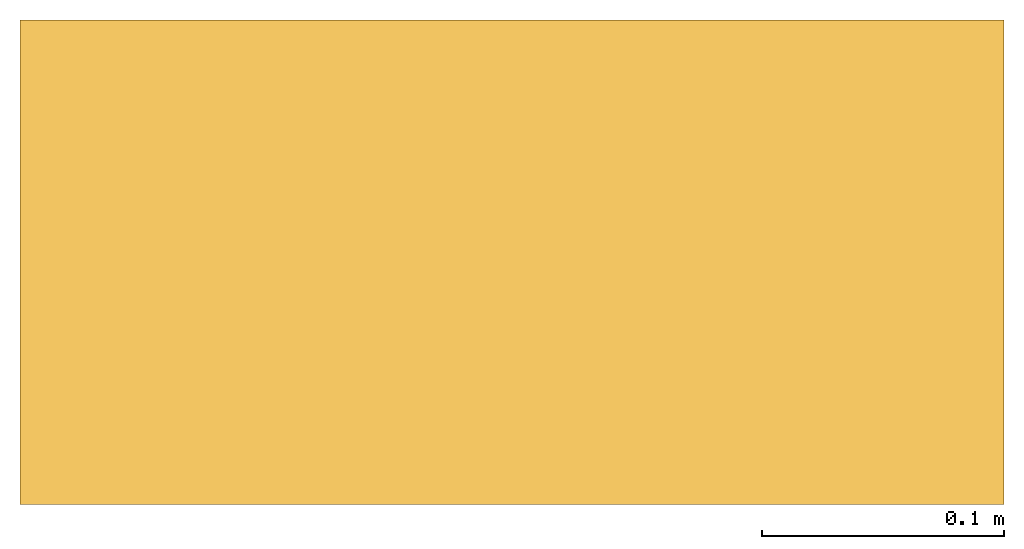
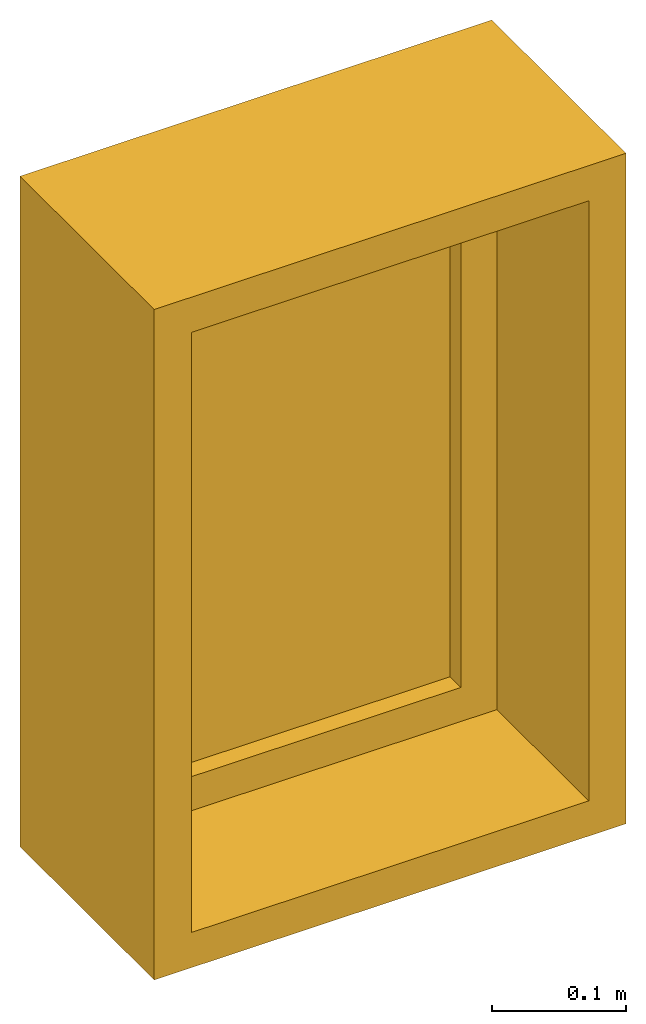
# One storey: 1 window.
"""IFC4 building model written with IfcOpenShell, lengths in millimetres."""

from ifc_helpers import new_model, entity, si_unit, converted_unit, derived_unit, direction, frame, origin, origin_with_axes, origin_2d_with_axis, place, context, subcontext, project, spatial, polyline, rectangle, outline, extrude, source, transform, mapped, material, constituent, constituent_set, type_object, type_shapes, element, save


model = new_model("IFC4")

# Units and contexts
model_context = context("Model", 3, precision=0.01, world=origin(), true_north=direction((6.12303176911189e-17, 1.0)))
body_context = subcontext(model_context, "Body", "Model", "MODEL_VIEW")
ifc_project = project(units=[si_unit("LENGTHUNIT", "METRE", prefix="MILLI"), si_unit("AREAUNIT", "SQUARE_METRE"), si_unit("VOLUMEUNIT", "CUBIC_METRE"), converted_unit("PLANEANGLEUNIT", "DEGREE", entity("IfcRatioMeasure", 0.0174532925199433), si_unit("PLANEANGLEUNIT", "RADIAN"), dimensions=[0, 0, 0, 0, 0, 0, 0]), si_unit("MASSUNIT", "GRAM", prefix="KILO"), derived_unit("MASSDENSITYUNIT", [(si_unit("MASSUNIT", "GRAM", prefix="KILO"), 1), (si_unit("LENGTHUNIT", "METRE"), -3)]), derived_unit("MOMENTOFINERTIAUNIT", [(si_unit("LENGTHUNIT", "METRE"), 4)]), si_unit("TIMEUNIT", "SECOND"), si_unit("FREQUENCYUNIT", "HERTZ"), si_unit("THERMODYNAMICTEMPERATUREUNIT", "DEGREE_CELSIUS"), derived_unit("THERMALTRANSMITTANCEUNIT", [(si_unit("MASSUNIT", "GRAM", prefix="KILO"), 1), (si_unit("THERMODYNAMICTEMPERATUREUNIT", "KELVIN"), -1), (si_unit("TIMEUNIT", "SECOND"), -3)]), derived_unit("VOLUMETRICFLOWRATEUNIT", [(si_unit("LENGTHUNIT", "METRE"), 3), (si_unit("TIMEUNIT", "SECOND"), -1)]), si_unit("ELECTRICCURRENTUNIT", "AMPERE"), si_unit("ELECTRICVOLTAGEUNIT", "VOLT"), si_unit("POWERUNIT", "WATT"), si_unit("FORCEUNIT", "NEWTON", prefix="KILO"), si_unit("ILLUMINANCEUNIT", "LUX"), si_unit("LUMINOUSFLUXUNIT", "LUMEN"), si_unit("LUMINOUSINTENSITYUNIT", "CANDELA"), derived_unit("USERDEFINED", [(si_unit("MASSUNIT", "GRAM", prefix="KILO"), -1), (si_unit("LENGTHUNIT", "METRE"), -2), (si_unit("TIMEUNIT", "SECOND"), 3), (si_unit("LUMINOUSFLUXUNIT", "LUMEN"), 1)]), derived_unit("LINEARVELOCITYUNIT", [(si_unit("LENGTHUNIT", "METRE"), 1), (si_unit("TIMEUNIT", "SECOND"), -1)]), si_unit("PRESSUREUNIT", "PASCAL"), derived_unit("USERDEFINED", [(si_unit("LENGTHUNIT", "METRE"), -2), (si_unit("MASSUNIT", "GRAM", prefix="KILO"), 1), (si_unit("TIMEUNIT", "SECOND"), -2)]), derived_unit("LINEARFORCEUNIT", [(si_unit("MASSUNIT", "GRAM", prefix="KILO"), 1), (si_unit("LENGTHUNIT", "METRE"), 1), (si_unit("TIMEUNIT", "SECOND"), -2), (si_unit("LENGTHUNIT", "METRE"), -1)]), derived_unit("PLANARFORCEUNIT", [(si_unit("MASSUNIT", "GRAM", prefix="KILO"), 1), (si_unit("LENGTHUNIT", "METRE"), 1), (si_unit("TIMEUNIT", "SECOND"), -2), (si_unit("LENGTHUNIT", "METRE"), -2)])], contexts=[model_context])

# Site, building, storey
site_placement = place(None, origin())
site = spatial("IfcSite", under=ifc_project, at=site_placement, CompositionType="ELEMENT")
building_placement = place(site_placement, origin())
building = spatial("IfcBuilding", under=site, at=building_placement, CompositionType="ELEMENT")
storey_placement = place(building_placement, origin())
storey = spatial("IfcBuildingStorey", under=building, at=storey_placement, Name="Niveau 1", CompositionType="ELEMENT", Elevation=0.0)

# Window
ifc_material_1 = material(Category="Pas d")
ifc_constituent_1 = constituent(ifc_material_1, Category="Pas d")
ifc_material_2 = material(Name="Verre 441", Category="Pas d")
ifc_constituent_2 = constituent(ifc_material_2, Name="Verre 441", Category="Pas d")
ifc_constituent_set = constituent_set(constituents=[ifc_constituent_1, ifc_constituent_2])
window_type = type_object("IfcWindowType", Name="Fixe:0406 x 0610mm:0406 x 0610mm : Fixe:0406 x 0610mm", ParameterTakesPrecedence=False, PartitioningType="NOTDEFINED", PredefinedType="WINDOW", material=ifc_constituent_set)
shared_shape = source(origin(), body_context, "Body", "SweptSolid", [
    extrude(outline(polyline([(-305.0, -203.0), (305.0, -203.0), (305.0, 203.0), (-305.0, 203.0), (-305.0, -203.0)]), holes=[polyline([(273.0, 171.0), (273.0, -171.0), (-273.0, -171.0), (-273.0, 171.0), (273.0, 171.0)])]), frame((203.0, 2.0, 305.0), z_axis=(0.0, 1.0, 0.0), x_axis=(0.0, 0.0, -1.0)), (0.0, 0.0, 1.0), 136.999999999973),
    extrude(outline(polyline([(-305.0, -203.0), (305.0, -203.0), (305.0, 203.0), (-305.0, 203.0), (-305.0, -203.0)]), holes=[polyline([(286.0, 184.0), (286.0, -184.0), (-286.0, -184.0), (-286.0, 184.0), (286.0, 184.0)])]), frame((203.0, 139.0, 305.0), z_axis=(0.0, 1.0, 0.0), x_axis=(0.0, 0.0, -1.0)), (0.0, 0.0, 1.0), 63.0000000000274),
    extrude(outline(polyline([(-286.0, -184.0), (286.0, -184.0), (286.0, 184.0), (-286.0, 184.0), (-286.0, -184.0)]), holes=[polyline([(242.0, 140.0), (242.0, -140.0), (-242.0, -140.0), (-242.0, 140.0), (242.0, 140.0)])]), frame((203.0, 139.0, 305.0), z_axis=(0.0, 1.0, 0.0), x_axis=(0.0, 0.0, -1.0)), (0.0, 0.0, 1.0), 44.0000000000274),
    extrude(rectangle(XDim=279.999999999997, YDim=12.0, at=origin_2d_with_axis()), frame((203.0, 161.0, 63.0)), (0.0, 0.0, 1.0), 484.000000000008),
])
type_shapes(window_type, [shared_shape])
window_placement = place(storey_placement, origin_with_axes())
element("IfcWindow", 1, at=window_placement, inside=storey, type_object=window_type, Name="Window", PredefinedType="NOTDEFINED", context=body_context, shape_type="MappedRepresentation", body=[
    mapped(shared_shape, transform((0.0, 0.0, 0.0), x_axis=(1.0, 0.0, 0.0), y_axis=(0.0, 1.0, 0.0), z_axis=(0.0, 0.0, 1.0), scale=1.0)),
])

save(model, "model.ifc")
